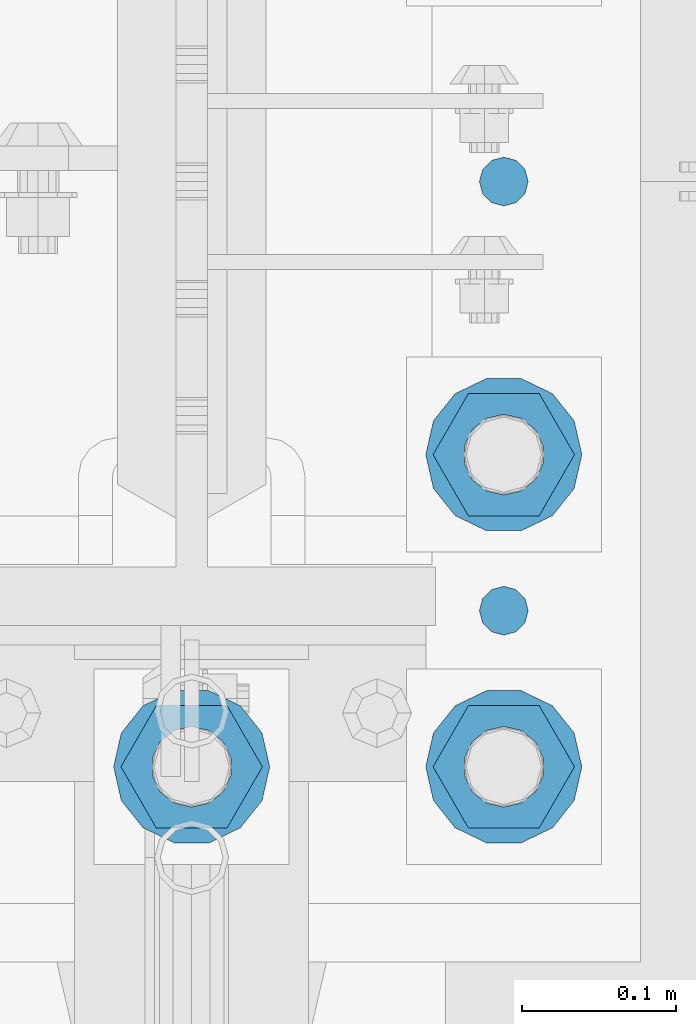
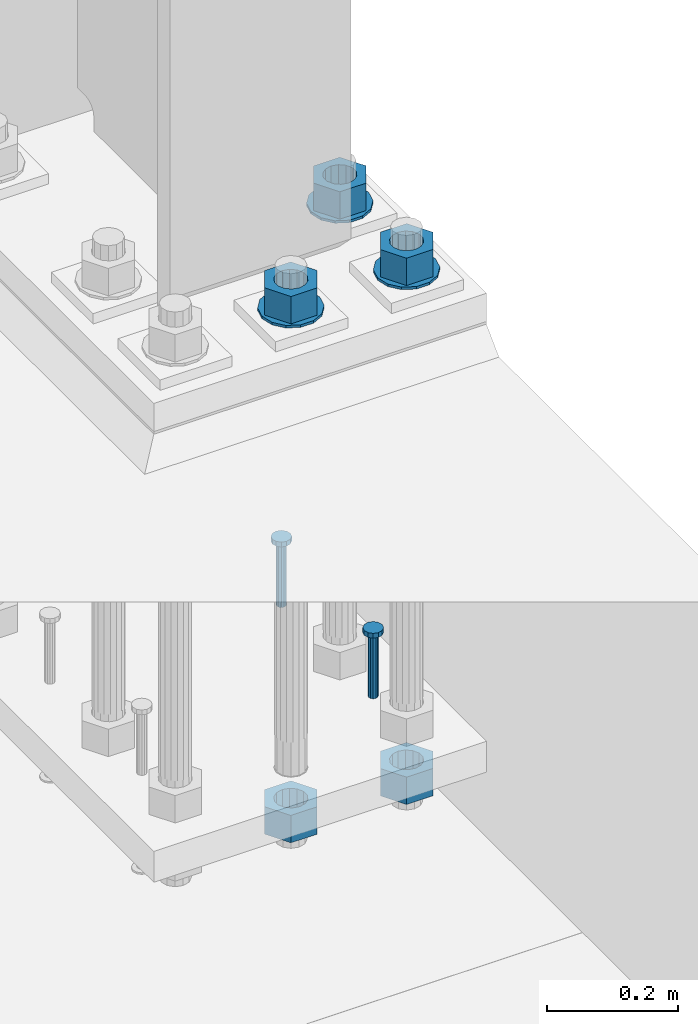
# One storey, part 857 of 1876: 10 columns, 1 element without a shape of its own.
"""IFC2X3 building model written with IfcOpenShell, lengths in millimetres."""

import ifcopenshell
import ifcopenshell.guid

model = None  # the IFC model being written
_history = None  # IfcOwnerHistory: only IFC2X3 demands one
_inside = {}  # id of a spatial element -> (the spatial element, [elements in it])
_under = {}  # id of a project, library or spatial element -> (it, [spatial elements below it])
_declared = {}  # id of a project -> (the project, [libraries it declares])
_typed = {}  # id of a type object -> (the type object, [elements of that type])
_made_of = {}  # id of a material, layer set ... -> (it, [elements and type objects made of it])


def new_model(schema):
    """Start an empty IFC model of exactly this schema.

    Asked for "IFC4X3", IfcOpenShell would pick the latest addendum, in which some entities
    have other attributes; the version numbers below select the first issue.
    IFC2X3 requires an IfcOwnerHistory on every rooted entity: one is made here for all.
    """
    global model, _history
    if schema == "IFC4X3":
        model = ifcopenshell.file(schema_version=(4, 3, 0, 0))
    else:
        model = ifcopenshell.file(schema=schema)
    _inside.clear()
    _under.clear()
    _declared.clear()
    _typed.clear()
    _made_of.clear()
    _history = None
    if model.schema == "IFC2X3":
        org = make("IfcOrganization", Name="unknown")
        user = make(
            "IfcPersonAndOrganization",
            ThePerson=make("IfcPerson", FamilyName="unknown"),
            TheOrganization=org,
        )
        app = make(
            "IfcApplication",
            ApplicationDeveloper=org,
            Version="unknown",
            ApplicationFullName="unknown",
            ApplicationIdentifier="unknown",
        )
        _history = make(
            "IfcOwnerHistory",
            OwningUser=user,
            OwningApplication=app,
            ChangeAction="ADDED",
            CreationDate=0,
        )
    return model


def make(cls, **values):
    """One entity of the class cls with the attributes given. An attribute that is None is left unset."""
    return model.create_entity(
        cls, **{name: value for name, value in values.items() if value is not None}
    )


def rooted(cls, **values):
    """An entity with a GlobalId (a new one), such as an element, a storey or a relation."""
    return make(cls, GlobalId=ifcopenshell.guid.new(), OwnerHistory=_history, **values)


def si_unit(unit_type, name, prefix=None):
    """IfcSIUnit, for example si_unit("LENGTHUNIT", "METRE", prefix="MILLI")."""
    return make("IfcSIUnit", UnitType=unit_type, Prefix=prefix, Name=name)


def assignment(units):
    """IfcUnitAssignment: the units of a project."""
    return None if units is None else make("IfcUnitAssignment", Units=units)


def point(xyz):
    """IfcCartesianPoint."""
    return None if xyz is None else make("IfcCartesianPoint", Coordinates=xyz)


def direction(xyz):
    """IfcDirection."""
    return None if xyz is None else make("IfcDirection", DirectionRatios=xyz)


def frame(location, z_axis=None, x_axis=None):
    """IfcAxis2Placement3D, a coordinate frame: its origin and axes. An axis left out is left unset."""
    return make(
        "IfcAxis2Placement3D",
        Location=point(location),
        Axis=direction(z_axis),
        RefDirection=direction(x_axis),
    )


def origin_with_axes():
    """The frame at (0, 0, 0) with the z axis (0, 0, 1) and the x axis (1, 0, 0) written out."""
    return frame((0.0, 0.0, 0.0), z_axis=(0.0, 0.0, 1.0), x_axis=(1.0, 0.0, 0.0))


def place(relative_to, where):
    """IfcLocalPlacement: puts the frame where relative to a parent placement (None: the world)."""
    return make(
        "IfcLocalPlacement", PlacementRelTo=relative_to, RelativePlacement=where
    )


def context(
    kind, dimensions, precision=None, world=None, true_north=None, identifier=None
):
    """IfcGeometricRepresentationContext, for example the 3D "Model" context."""
    return make(
        "IfcGeometricRepresentationContext",
        ContextIdentifier=identifier,
        ContextType=kind,
        CoordinateSpaceDimension=dimensions,
        Precision=precision,
        WorldCoordinateSystem=world,
        TrueNorth=true_north,
    )


def subcontext(parent, identifier, kind, view, scale=None):
    """IfcGeometricRepresentationSubContext, for example "Body" below "Model"."""
    return make(
        "IfcGeometricRepresentationSubContext",
        ContextIdentifier=identifier,
        ContextType=kind,
        ParentContext=parent,
        TargetScale=scale,
        TargetView=view,
    )


def project(units=None, contexts=None):
    """IfcProject with its units and contexts."""
    return rooted(
        "IfcProject",
        Name="project",
        RepresentationContexts=contexts,
        UnitsInContext=assignment(units),
    )


def spatial(cls, under=None, at=None, **own):
    """A site, building, storey or space (cls), placed at a placement, below another one or the project."""
    s = rooted(cls, ObjectPlacement=at, **own)
    if under is not None:
        _under.setdefault(under.id(), (under, []))[1].append(s)
    return s


def faces_of(points, faces, orient=None, outer=None):
    """IfcFace entities. A face is a list of loops; a loop is a list of indices into points, from 0.

    orient and outer hold one flag for each loop. By default every Orientation is true, the
    first loop of a face is its IfcFaceOuterBound and the others are IfcFaceBound.
    """
    made = []
    for i, loops in enumerate(faces):
        bounds = []
        for j, loop in enumerate(loops):
            is_outer = j == 0 if outer is None else outer[i][j]
            bounds.append(
                make(
                    "IfcFaceOuterBound" if is_outer else "IfcFaceBound",
                    Bound=make("IfcPolyLoop", Polygon=[points[k] for k in loop]),
                    Orientation=True if orient is None else orient[i][j],
                )
            )
        made.append(make("IfcFace", Bounds=bounds))
    return made


def faceted_brep(points, faces, orient=None, outer=None, voids=None):
    """IfcFacetedBrep: a solid bounded by flat faces; with voids (closed shells), ...WithVoids."""
    shared = [point(p) for p in points]
    hull = make("IfcClosedShell", CfsFaces=faces_of(shared, faces, orient, outer))
    if voids is None:
        return make("IfcFacetedBrep", Outer=hull)
    return make(
        "IfcFacetedBrepWithVoids",
        Outer=hull,
        Voids=[
            make(cls, CfsFaces=faces_of(shared, fs, o, b)) for cls, fs, o, b in voids
        ],
    )


def shape(context_of_items, identifier, shape_type, items):
    """IfcShapeRepresentation: the items that make up one representation, for example the "Body"."""
    return make(
        "IfcShapeRepresentation",
        ContextOfItems=context_of_items,
        RepresentationIdentifier=identifier,
        RepresentationType=shape_type,
        Items=items,
    )


def material(Name=None, Category=None):
    """IfcMaterial."""
    return make("IfcMaterial", Name=Name, Category=Category)


def made_of(thing, what):
    """Note that an element or type object is made of a material, layer set ...; save() writes the relation."""
    if what is not None:
        _made_of.setdefault(what.id(), (what, []))[1].append(thing)
    return thing


def type_object(cls, material=None, **own):
    """A type object (cls), such as IfcWallType, which elements share."""
    return made_of(rooted(cls, **own), material)


def element(
    cls,
    number,
    at=None,
    inside=None,
    cuts=None,
    type_object=None,
    material=None,
    context=None,
    identifier="Body",
    shape_type=None,
    held_by="IfcProductDefinitionShape",
    body=None,
    shapes=None,
    **own,
):
    """One element of the class cls, such as IfcWall. Its Tag is "e" and its number.

    at: its placement. inside: the storey or other place that contains it. cuts: it is an
    opening in that element (IfcRelVoidsElement). A single representation is given by context,
    identifier, shape_type and body (its items); several are given by shapes. held_by: the class
    of the entity that holds the representations. save() writes the other relations.
    """
    e = rooted(cls, Tag="e%d" % number, ObjectPlacement=at, **own)
    if body is not None:
        shapes = [shape(context, identifier, shape_type, body)]
    if shapes is not None:
        e.Representation = make(held_by, Representations=shapes)
    if inside is not None:
        _inside.setdefault(inside.id(), (inside, []))[1].append(e)
    if cuts is not None:
        rooted(
            "IfcRelVoidsElement", RelatingBuildingElement=cuts, RelatedOpeningElement=e
        )
    if type_object is not None:
        _typed.setdefault(type_object.id(), (type_object, []))[1].append(e)
    return made_of(e, material)


def aggregate(whole, parts):
    """IfcRelAggregates: a whole, such as a stair, and the parts it consists of."""
    return rooted("IfcRelAggregates", RelatingObject=whole, RelatedObjects=parts)


def save(model, path):
    """Write the relations noted so far, then the file.

    IfcRelAggregates (storeys below a building ...), IfcRelContainedInSpatialStructure (elements
    in a storey), IfcRelDefinesByType, IfcRelAssociatesMaterial and IfcRelDeclares: one each for
    every whole, place, type object, material and project.
    """
    for whole, parts in _under.values():
        aggregate(whole, parts)
    for where, things in _inside.values():
        rooted(
            "IfcRelContainedInSpatialStructure",
            RelatedElements=things,
            RelatingStructure=where,
        )
    for kind, things in _typed.values():
        rooted("IfcRelDefinesByType", RelatedObjects=things, RelatingType=kind)
    for what, things in _made_of.values():
        rooted("IfcRelAssociatesMaterial", RelatedObjects=things, RelatingMaterial=what)
    for by, libraries in _declared.values():
        rooted("IfcRelDeclares", RelatingContext=by, RelatedDefinitions=libraries)
    model.write(path)


model = new_model("IFC2X3")

# Units and contexts
model_context = context("Model", 3, precision=1e-05, world=origin_with_axes())
body_context = subcontext(model_context, "Body", "Model", "MODEL_VIEW")
ifc_project = project(units=[si_unit("LENGTHUNIT", "METRE", prefix="MILLI"), si_unit("AREAUNIT", "SQUARE_METRE"), si_unit("VOLUMEUNIT", "CUBIC_METRE"), si_unit("MASSUNIT", "GRAM", prefix="KILO"), si_unit("TIMEUNIT", "SECOND"), si_unit("PLANEANGLEUNIT", "RADIAN"), si_unit("SOLIDANGLEUNIT", "STERADIAN"), si_unit("THERMODYNAMICTEMPERATUREUNIT", "DEGREE_CELSIUS"), si_unit("LUMINOUSINTENSITYUNIT", "LUMEN")], contexts=[model_context])

# Site, building, storey
site_placement = place(None, origin_with_axes())
site = spatial("IfcSite", under=ifc_project, at=site_placement, CompositionType="ELEMENT")
building_placement = place(site_placement, origin_with_axes())
building = spatial("IfcBuilding", under=site, at=building_placement, Name="Undefined", CompositionType="ELEMENT")
storey_placement = place(building_placement, origin_with_axes())
storey = spatial("IfcBuildingStorey", under=building, at=storey_placement, Name="Undefined", CompositionType="ELEMENT", Elevation=0.0)

# Assembly, columns
assembly_placement = place(storey_placement, origin_with_axes())
assembly = element("IfcElementAssembly", 1, at=assembly_placement, inside=storey, Name="TEMPLATE", AssemblyPlace="NOTDEFINED", PredefinedType="RIGID_FRAME")
ifc_material_1 = material(Name="STEEL/F436")
column_type_1 = type_object("IfcColumnType", Name="2_WASHER", PredefinedType="NOTDEFINED")
column_1_placement = place(assembly_placement, frame((7620.0, 7239.0, 119.0625), z_axis=(0.0, -1.0, 0.0), x_axis=(0.0, 0.0, -1.0)))
column_1 = element("IfcColumn", 2, at=column_1_placement, type_object=column_type_1, material=ifc_material_1, Name="WASHER", ObjectType="2_WASHER", context=body_context, shape_type="Brep", body=[
    faceted_brep([(0.0, -50.7999992370605, 9.09494701772928e-13), (0.0, -45.7692178020588, -22.0412936161442), (4.7625, -45.7692178020588, -22.0412936161442), (4.7625, -50.7999992370605, 9.09494701772928e-13), (0.0, -31.6732814587394, -39.7170387128856), (4.7625, -31.6732814587394, -39.7170387128856), (0.0, -11.3040632752118, -49.5263371950259), (4.7625, -11.3040632752118, -49.5263371950259), (0.0, 11.30406327521, -49.5263371950264), (4.7625, 11.30406327521, -49.5263371950264), (0.0, 31.6732814587385, -39.7170387128867), (4.7625, 31.6732814587385, -39.7170387128867), (0.0, 45.7692178020579, -22.041293616146), (4.7625, 45.7692178020579, -22.041293616146), (0.0, 50.7999992370605, -9.09494701772928e-13), (4.7625, 50.7999992370605, -9.09494701772928e-13), (0.0, 45.7692178020588, 22.0412936161442), (4.7625, 45.7692178020588, 22.0412936161442), (0.0, 31.6732814587394, 39.7170387128856), (4.7625, 31.6732814587394, 39.7170387128856), (0.0, 11.3040632752118, 49.5263371950259), (4.7625, 11.3040632752118, 49.5263371950259), (0.0, -11.30406327521, 49.5263371950264), (4.7625, -11.30406327521, 49.5263371950264), (0.0, -31.6732814587385, 39.7170387128867), (4.7625, -31.6732814587385, 39.7170387128867), (0.0, -45.7692178020579, 22.041293616146), (4.7625, -45.7692178020579, 22.041293616146), (0.0, 0.0, 26.9869995117188), (0.0, 11.7093983825444, 24.3146012721213), (4.7625, 11.7093983825444, 24.3146012721213), (4.7625, 0.0, 26.9869995117188), (0.0, 21.0996520289491, 16.8262864224157), (4.7625, 21.0996520289491, 16.8262864224157), (0.0, 26.3108629296712, 6.00524193584533), (4.7625, 26.3108629296712, 6.00524193584533), (0.0, 26.3108629296712, -6.00524193584533), (4.7625, 26.3108629296712, -6.00524193584533), (0.0, 21.0996520289491, -16.8262864224157), (4.7625, 21.0996520289491, -16.8262864224157), (0.0, 11.7093983825444, -24.3146012721213), (4.7625, 11.7093983825444, -24.3146012721213), (0.0, 0.0, -26.9869995117188), (4.7625, 0.0, -26.9869995117188), (0.0, -11.7093983825444, -24.3146012721213), (4.7625, -11.7093983825444, -24.3146012721213), (0.0, -21.0996520289491, -16.8262864224157), (4.7625, -21.0996520289491, -16.8262864224157), (0.0, -26.3108629296712, -6.00524193584533), (4.7625, -26.3108629296712, -6.00524193584533), (0.0, -26.3108629296712, 6.00524193584533), (4.7625, -26.3108629296712, 6.00524193584533), (0.0, -21.0996520289491, 16.8262864224157), (4.7625, -21.0996520289491, 16.8262864224157), (0.0, -11.7093983825444, 24.3146012721213), (4.7625, -11.7093983825444, 24.3146012721213)], [[[0, 1, 2, 3]], [[1, 4, 5, 2]], [[4, 6, 7, 5]], [[6, 8, 9, 7]], [[8, 10, 11, 9]], [[10, 12, 13, 11]], [[12, 14, 15, 13]], [[14, 16, 17, 15]], [[16, 18, 19, 17]], [[18, 20, 21, 19]], [[20, 22, 23, 21]], [[22, 24, 25, 23]], [[24, 26, 27, 25]], [[26, 0, 3, 27]], [[28, 29, 30, 31]], [[29, 32, 33, 30]], [[32, 34, 35, 33]], [[34, 36, 37, 35]], [[36, 38, 39, 37]], [[38, 40, 41, 39]], [[40, 42, 43, 41]], [[42, 44, 45, 43]], [[44, 46, 47, 45]], [[46, 48, 49, 47]], [[48, 50, 51, 49]], [[50, 52, 53, 51]], [[52, 54, 55, 53]], [[54, 28, 31, 55]], [[5, 7, 9, 11, 13, 15, 17, 19, 21, 23, 25, 27, 3, 2], [33, 35, 37, 39, 41, 43, 45, 47, 49, 51, 53, 55, 31, 30]], [[26, 24, 22, 20, 18, 16, 14, 12, 10, 8, 6, 4, 1, 0], [54, 52, 50, 48, 46, 44, 42, 40, 38, 36, 34, 32, 29, 28]]]),
])
column_2_placement = place(assembly_placement, frame((7823.2, 7239.0, 119.0625), z_axis=(0.0, 1.0, 0.0), x_axis=(0.0, 0.0, -1.0)))
column_2 = element("IfcColumn", 3, at=column_2_placement, type_object=column_type_1, material=ifc_material_1, Name="WASHER", ObjectType="2_WASHER", context=body_context, shape_type="Brep", body=[
    faceted_brep([(0.0, -50.7999992370605, 9.09494701772928e-13), (0.0, -45.7692178020588, -22.0412936161442), (4.7625, -45.7692178020588, -22.0412936161442), (4.7625, -50.7999992370605, 9.09494701772928e-13), (0.0, -31.6732814587394, -39.7170387128856), (4.7625, -31.6732814587394, -39.7170387128856), (0.0, -11.3040632752118, -49.5263371950259), (4.7625, -11.3040632752118, -49.5263371950259), (0.0, 11.30406327521, -49.5263371950264), (4.7625, 11.30406327521, -49.5263371950264), (0.0, 31.6732814587385, -39.7170387128867), (4.7625, 31.6732814587385, -39.7170387128867), (0.0, 45.7692178020579, -22.041293616146), (4.7625, 45.7692178020579, -22.041293616146), (0.0, 50.7999992370605, -9.09494701772928e-13), (4.7625, 50.7999992370605, -9.09494701772928e-13), (0.0, 45.7692178020588, 22.0412936161442), (4.7625, 45.7692178020588, 22.0412936161442), (0.0, 31.6732814587394, 39.7170387128856), (4.7625, 31.6732814587394, 39.7170387128856), (0.0, 11.3040632752118, 49.5263371950259), (4.7625, 11.3040632752118, 49.5263371950259), (0.0, -11.30406327521, 49.5263371950264), (4.7625, -11.30406327521, 49.5263371950264), (0.0, -31.6732814587385, 39.7170387128867), (4.7625, -31.6732814587385, 39.7170387128867), (0.0, -45.7692178020579, 22.041293616146), (4.7625, -45.7692178020579, 22.041293616146), (0.0, 0.0, 26.9869995117188), (0.0, 11.7093983825444, 24.3146012721213), (4.7625, 11.7093983825444, 24.3146012721213), (4.7625, 0.0, 26.9869995117188), (0.0, 21.0996520289491, 16.8262864224157), (4.7625, 21.0996520289491, 16.8262864224157), (0.0, 26.3108629296712, 6.00524193584533), (4.7625, 26.3108629296712, 6.00524193584533), (0.0, 26.3108629296712, -6.00524193584533), (4.7625, 26.3108629296712, -6.00524193584533), (0.0, 21.0996520289491, -16.8262864224157), (4.7625, 21.0996520289491, -16.8262864224157), (0.0, 11.7093983825444, -24.3146012721213), (4.7625, 11.7093983825444, -24.3146012721213), (0.0, 0.0, -26.9869995117188), (4.7625, 0.0, -26.9869995117188), (0.0, -11.7093983825444, -24.3146012721213), (4.7625, -11.7093983825444, -24.3146012721213), (0.0, -21.0996520289491, -16.8262864224157), (4.7625, -21.0996520289491, -16.8262864224157), (0.0, -26.3108629296712, -6.00524193584533), (4.7625, -26.3108629296712, -6.00524193584533), (0.0, -26.3108629296712, 6.00524193584533), (4.7625, -26.3108629296712, 6.00524193584533), (0.0, -21.0996520289491, 16.8262864224157), (4.7625, -21.0996520289491, 16.8262864224157), (0.0, -11.7093983825444, 24.3146012721213), (4.7625, -11.7093983825444, 24.3146012721213)], [[[0, 1, 2, 3]], [[1, 4, 5, 2]], [[4, 6, 7, 5]], [[6, 8, 9, 7]], [[8, 10, 11, 9]], [[10, 12, 13, 11]], [[12, 14, 15, 13]], [[14, 16, 17, 15]], [[16, 18, 19, 17]], [[18, 20, 21, 19]], [[20, 22, 23, 21]], [[22, 24, 25, 23]], [[24, 26, 27, 25]], [[26, 0, 3, 27]], [[28, 29, 30, 31]], [[29, 32, 33, 30]], [[32, 34, 35, 33]], [[34, 36, 37, 35]], [[36, 38, 39, 37]], [[38, 40, 41, 39]], [[40, 42, 43, 41]], [[42, 44, 45, 43]], [[44, 46, 47, 45]], [[46, 48, 49, 47]], [[48, 50, 51, 49]], [[50, 52, 53, 51]], [[52, 54, 55, 53]], [[54, 28, 31, 55]], [[5, 7, 9, 11, 13, 15, 17, 19, 21, 23, 25, 27, 3, 2], [33, 35, 37, 39, 41, 43, 45, 47, 49, 51, 53, 55, 31, 30]], [[26, 24, 22, 20, 18, 16, 14, 12, 10, 8, 6, 4, 1, 0], [54, 52, 50, 48, 46, 44, 42, 40, 38, 36, 34, 32, 29, 28]]]),
])
column_3_placement = place(assembly_placement, frame((7823.2, 7442.2, 119.0625), z_axis=(0.0, 1.0, 0.0), x_axis=(0.0, 0.0, -1.0)))
column_3 = element("IfcColumn", 4, at=column_3_placement, type_object=column_type_1, material=ifc_material_1, Name="WASHER", ObjectType="2_WASHER", context=body_context, shape_type="Brep", body=[
    faceted_brep([(0.0, -50.7999992370605, 9.09494701772928e-13), (0.0, -45.7692178020588, -22.0412936161442), (4.7625, -45.7692178020588, -22.0412936161442), (4.7625, -50.7999992370605, 9.09494701772928e-13), (0.0, -31.6732814587394, -39.7170387128856), (4.7625, -31.6732814587394, -39.7170387128856), (0.0, -11.3040632752118, -49.5263371950259), (4.7625, -11.3040632752118, -49.5263371950259), (0.0, 11.30406327521, -49.5263371950264), (4.7625, 11.30406327521, -49.5263371950264), (0.0, 31.6732814587385, -39.7170387128867), (4.7625, 31.6732814587385, -39.7170387128867), (0.0, 45.7692178020579, -22.041293616146), (4.7625, 45.7692178020579, -22.041293616146), (0.0, 50.7999992370605, -9.09494701772928e-13), (4.7625, 50.7999992370605, -9.09494701772928e-13), (0.0, 45.7692178020588, 22.0412936161442), (4.7625, 45.7692178020588, 22.0412936161442), (0.0, 31.6732814587394, 39.7170387128856), (4.7625, 31.6732814587394, 39.7170387128856), (0.0, 11.3040632752118, 49.5263371950259), (4.7625, 11.3040632752118, 49.5263371950259), (0.0, -11.30406327521, 49.5263371950264), (4.7625, -11.30406327521, 49.5263371950264), (0.0, -31.6732814587385, 39.7170387128867), (4.7625, -31.6732814587385, 39.7170387128867), (0.0, -45.7692178020579, 22.041293616146), (4.7625, -45.7692178020579, 22.041293616146), (0.0, 0.0, 26.9869995117188), (0.0, 11.7093983825444, 24.3146012721213), (4.7625, 11.7093983825444, 24.3146012721213), (4.7625, 0.0, 26.9869995117188), (0.0, 21.0996520289491, 16.8262864224157), (4.7625, 21.0996520289491, 16.8262864224157), (0.0, 26.3108629296712, 6.00524193584533), (4.7625, 26.3108629296712, 6.00524193584533), (0.0, 26.3108629296712, -6.00524193584533), (4.7625, 26.3108629296712, -6.00524193584533), (0.0, 21.0996520289491, -16.8262864224157), (4.7625, 21.0996520289491, -16.8262864224157), (0.0, 11.7093983825444, -24.3146012721213), (4.7625, 11.7093983825444, -24.3146012721213), (0.0, 0.0, -26.9869995117188), (4.7625, 0.0, -26.9869995117188), (0.0, -11.7093983825444, -24.3146012721213), (4.7625, -11.7093983825444, -24.3146012721213), (0.0, -21.0996520289491, -16.8262864224157), (4.7625, -21.0996520289491, -16.8262864224157), (0.0, -26.3108629296712, -6.00524193584533), (4.7625, -26.3108629296712, -6.00524193584533), (0.0, -26.3108629296712, 6.00524193584533), (4.7625, -26.3108629296712, 6.00524193584533), (0.0, -21.0996520289491, 16.8262864224157), (4.7625, -21.0996520289491, 16.8262864224157), (0.0, -11.7093983825444, 24.3146012721213), (4.7625, -11.7093983825444, 24.3146012721213)], [[[0, 1, 2, 3]], [[1, 4, 5, 2]], [[4, 6, 7, 5]], [[6, 8, 9, 7]], [[8, 10, 11, 9]], [[10, 12, 13, 11]], [[12, 14, 15, 13]], [[14, 16, 17, 15]], [[16, 18, 19, 17]], [[18, 20, 21, 19]], [[20, 22, 23, 21]], [[22, 24, 25, 23]], [[24, 26, 27, 25]], [[26, 0, 3, 27]], [[28, 29, 30, 31]], [[29, 32, 33, 30]], [[32, 34, 35, 33]], [[34, 36, 37, 35]], [[36, 38, 39, 37]], [[38, 40, 41, 39]], [[40, 42, 43, 41]], [[42, 44, 45, 43]], [[44, 46, 47, 45]], [[46, 48, 49, 47]], [[48, 50, 51, 49]], [[50, 52, 53, 51]], [[52, 54, 55, 53]], [[54, 28, 31, 55]], [[5, 7, 9, 11, 13, 15, 17, 19, 21, 23, 25, 27, 3, 2], [33, 35, 37, 39, 41, 43, 45, 47, 49, 51, 53, 55, 31, 30]], [[26, 24, 22, 20, 18, 16, 14, 12, 10, 8, 6, 4, 1, 0], [54, 52, 50, 48, 46, 44, 42, 40, 38, 36, 34, 32, 29, 28]]]),
])
ifc_material_2 = material(Name="STEEL/A108")
column_type_2 = type_object("IfcColumnType", Name="5/8-DIA_HEADED ANCHOR STUD", PredefinedType="NOTDEFINED")
column_4_placement = place(assembly_placement, frame((7823.2, 7340.6, -736.6), z_axis=(1.0, 0.0, 0.0), x_axis=(0.0, 0.0, 1.0)))
column_4 = element("IfcColumn", 5, at=column_4_placement, type_object=column_type_2, material=ifc_material_2, Name="HEADED ANCHOR STUD", ObjectType="5/8-DIA_HEADED ANCHOR STUD", context=body_context, shape_type="Brep", body=[
    faceted_brep([(0.0, -7.94000005722046, 0.0), (0.0, -6.86999988555908, -3.97000002861023), (116.84, -6.86999988555908, -3.97000002861023), (116.84, -7.94000005722046, 0.0), (0.0, -3.97000002861023, -6.86999988555908), (116.84, -3.97000002861023, -6.86999988555908), (0.0, 0.0, -7.94000005722046), (116.84, 0.0, -7.94000005722046), (0.0, 3.97000002861023, -6.86999988555908), (116.84, 3.97000002861023, -6.86999988555908), (0.0, 6.86999988555908, -3.97000002861023), (116.84, 6.86999988555908, -3.97000002861023), (0.0, 7.94000005722046, 0.0), (116.84, 7.94000005722046, 0.0), (0.0, 6.86999988555908, 3.97000002861023), (116.84, 6.86999988555908, 3.97000002861023), (0.0, 3.97000002861023, 6.86999988555908), (116.84, 3.97000002861023, 6.86999988555908), (0.0, 0.0, 7.94000005722046), (116.84, 0.0, 7.94000005722046), (0.0, -3.97000002861023, 6.86999988555908), (116.84, -3.97000002861023, 6.86999988555908), (0.0, -6.86999988555908, 3.97000002861023), (116.84, -6.86999988555908, 3.97000002861023), (118.11, -13.75, -7.94000005722046), (118.11, -15.8800001144409, 0.0), (118.11, -7.94000005722046, -13.75), (118.11, 0.0, -15.8800001144409), (118.11, 7.94000005722046, -13.75), (118.11, 13.75, -7.94000005722046), (118.11, 15.8800001144409, 0.0), (118.11, 13.75, 7.94000005722046), (118.11, 7.94000005722046, 13.75), (118.11, 0.0, 15.8800001144409), (118.11, -7.94000005722046, 13.75), (118.11, -13.75, 7.94000005722046), (127.0, -13.75, -7.94000005722046), (127.0, -15.8800001144409, 0.0), (127.0, -7.94000005722046, -13.75), (127.0, 0.0, -15.8800001144409), (127.0, 7.94000005722046, -13.75), (127.0, 13.75, -7.94000005722046), (127.0, 15.8800001144409, 0.0), (127.0, 13.75, 7.94000005722046), (127.0, 7.94000005722046, 13.75), (127.0, 0.0, 15.8800001144409), (127.0, -7.94000005722046, 13.75), (127.0, -13.75, 7.94000005722046)], [[[0, 1, 2, 3]], [[1, 4, 5, 2]], [[4, 6, 7, 5]], [[6, 8, 9, 7]], [[8, 10, 11, 9]], [[10, 12, 13, 11]], [[12, 14, 15, 13]], [[14, 16, 17, 15]], [[16, 18, 19, 17]], [[18, 20, 21, 19]], [[20, 22, 23, 21]], [[22, 0, 3, 23]], [[22, 20, 18, 16, 14, 12, 10, 8, 6, 4, 1, 0]], [[3, 2, 24, 25]], [[2, 5, 26, 24]], [[5, 7, 27, 26]], [[7, 9, 28, 27]], [[9, 11, 29, 28]], [[11, 13, 30, 29]], [[13, 15, 31, 30]], [[15, 17, 32, 31]], [[17, 19, 33, 32]], [[19, 21, 34, 33]], [[21, 23, 35, 34]], [[23, 3, 25, 35]], [[25, 24, 36, 37]], [[24, 26, 38, 36]], [[26, 27, 39, 38]], [[27, 28, 40, 39]], [[28, 29, 41, 40]], [[29, 30, 42, 41]], [[30, 31, 43, 42]], [[31, 32, 44, 43]], [[32, 33, 45, 44]], [[33, 34, 46, 45]], [[34, 35, 47, 46]], [[35, 25, 37, 47]], [[38, 39, 40, 41, 42, 43, 44, 45, 46, 47, 37, 36]]]),
])
column_5_placement = place(assembly_placement, frame((7823.2, 7620.0, -736.6), z_axis=(1.0, 0.0, 0.0), x_axis=(0.0, 0.0, 1.0)))
column_5 = element("IfcColumn", 6, at=column_5_placement, type_object=column_type_2, material=ifc_material_2, Name="HEADED ANCHOR STUD", ObjectType="5/8-DIA_HEADED ANCHOR STUD", context=body_context, shape_type="Brep", body=[
    faceted_brep([(0.0, -7.94000005722046, 0.0), (0.0, -6.86999988555908, -3.97000002861023), (116.84, -6.86999988555908, -3.97000002861023), (116.84, -7.94000005722046, 0.0), (0.0, -3.97000002861023, -6.86999988555908), (116.84, -3.97000002861023, -6.86999988555908), (0.0, 0.0, -7.94000005722046), (116.84, 0.0, -7.94000005722046), (0.0, 3.97000002861023, -6.86999988555908), (116.84, 3.97000002861023, -6.86999988555908), (0.0, 6.86999988555908, -3.97000002861023), (116.84, 6.86999988555908, -3.97000002861023), (0.0, 7.94000005722046, 0.0), (116.84, 7.94000005722046, 0.0), (0.0, 6.86999988555908, 3.97000002861023), (116.84, 6.86999988555908, 3.97000002861023), (0.0, 3.97000002861023, 6.86999988555908), (116.84, 3.97000002861023, 6.86999988555908), (0.0, 0.0, 7.94000005722046), (116.84, 0.0, 7.94000005722046), (0.0, -3.97000002861023, 6.86999988555908), (116.84, -3.97000002861023, 6.86999988555908), (0.0, -6.86999988555908, 3.97000002861023), (116.84, -6.86999988555908, 3.97000002861023), (118.11, -13.75, -7.94000005722046), (118.11, -15.8800001144409, 0.0), (118.11, -7.94000005722046, -13.75), (118.11, 0.0, -15.8800001144409), (118.11, 7.94000005722046, -13.75), (118.11, 13.75, -7.94000005722046), (118.11, 15.8800001144409, 0.0), (118.11, 13.75, 7.94000005722046), (118.11, 7.94000005722046, 13.75), (118.11, 0.0, 15.8800001144409), (118.11, -7.94000005722046, 13.75), (118.11, -13.75, 7.94000005722046), (127.0, -13.75, -7.94000005722046), (127.0, -15.8800001144409, 0.0), (127.0, -7.94000005722046, -13.75), (127.0, 0.0, -15.8800001144409), (127.0, 7.94000005722046, -13.75), (127.0, 13.75, -7.94000005722046), (127.0, 15.8800001144409, 0.0), (127.0, 13.75, 7.94000005722046), (127.0, 7.94000005722046, 13.75), (127.0, 0.0, 15.8800001144409), (127.0, -7.94000005722046, 13.75), (127.0, -13.75, 7.94000005722046)], [[[0, 1, 2, 3]], [[1, 4, 5, 2]], [[4, 6, 7, 5]], [[6, 8, 9, 7]], [[8, 10, 11, 9]], [[10, 12, 13, 11]], [[12, 14, 15, 13]], [[14, 16, 17, 15]], [[16, 18, 19, 17]], [[18, 20, 21, 19]], [[20, 22, 23, 21]], [[22, 0, 3, 23]], [[22, 20, 18, 16, 14, 12, 10, 8, 6, 4, 1, 0]], [[3, 2, 24, 25]], [[2, 5, 26, 24]], [[5, 7, 27, 26]], [[7, 9, 28, 27]], [[9, 11, 29, 28]], [[11, 13, 30, 29]], [[13, 15, 31, 30]], [[15, 17, 32, 31]], [[17, 19, 33, 32]], [[19, 21, 34, 33]], [[21, 23, 35, 34]], [[23, 3, 25, 35]], [[25, 24, 36, 37]], [[24, 26, 38, 36]], [[26, 27, 39, 38]], [[27, 28, 40, 39]], [[28, 29, 41, 40]], [[29, 30, 42, 41]], [[30, 31, 43, 42]], [[31, 32, 44, 43]], [[32, 33, 45, 44]], [[33, 34, 46, 45]], [[34, 35, 47, 46]], [[35, 25, 37, 47]], [[38, 39, 40, 41, 42, 43, 44, 45, 46, 47, 37, 36]]]),
])
ifc_material_3 = material(Name="STEEL/A563")
column_type_3 = type_object("IfcColumnType", Name="2_HEAVY_HEX_NUT", PredefinedType="NOTDEFINED")
column_6_placement = place(assembly_placement, frame((7620.0, 7239.0, 169.8625), z_axis=(0.0, -1.0, 0.0), x_axis=(0.0, 0.0, -1.0)))
column_6 = element("IfcColumn", 7, at=column_6_placement, type_object=column_type_3, material=ifc_material_3, Name="NUT", ObjectType="2_HEAVY_HEX_NUT", context=body_context, shape_type="Brep", body=[
    faceted_brep([(0.0, -46.0369987487793, 9.09494701772928e-13), (0.0, -23.0184993743896, -39.869213104248), (50.8, -23.0184993743896, -39.869213104248), (50.8, -46.0369987487793, 9.09494701772928e-13), (0.0, 23.0184993743896, -39.869213104248), (50.8, 23.0184993743896, -39.869213104248), (0.0, 46.0369987487793, -9.09494701772928e-13), (50.8, 46.0369987487793, -9.09494701772928e-13), (0.0, 23.0184993743896, 39.869213104248), (50.8, 23.0184993743896, 39.869213104248), (0.0, -23.0184993743896, 39.869213104248), (50.8, -23.0184993743896, 39.869213104248), (0.0, 0.0, 26.1940002441406), (0.0, 11.3650617044514, 23.5999013092769), (50.8, 11.3650617044513, 23.5999013092771), (50.8, 0.0, 26.1940002441406), (0.0, 20.4791109456437, 16.3316083006703), (50.8, 20.4791109456439, 16.3316083006703), (0.0, 25.5370200498346, 5.82867859874477), (50.8, 25.5370200498343, 5.82867859874455), (0.0, 25.5370200498346, -5.82867859874477), (50.8, 25.5370200498343, -5.82867859874455), (0.0, 20.4791109456437, -16.3316083006703), (50.8, 20.4791109456439, -16.3316083006703), (0.0, 11.3650617044514, -23.5999013092769), (50.8, 11.3650617044514, -23.5999013092771), (0.0, 0.0, -26.1940002441406), (50.8, 0.0, -26.1940002441406), (0.0, -11.3650617044514, -23.5999013092769), (50.8, -11.3650617044513, -23.5999013092771), (0.0, -20.4791109456437, -16.3316083006703), (50.8, -20.4791109456439, -16.3316083006703), (0.0, -25.5370200498346, -5.82867859874477), (50.8, -25.5370200498343, -5.82867859874455), (0.0, -25.5370200498346, 5.82867859874477), (50.8, -25.5370200498343, 5.82867859874455), (0.0, -20.4791109456437, 16.3316083006703), (50.8, -20.4791109456439, 16.3316083006703), (0.0, -11.3650617044514, 23.5999013092769), (50.8, -11.3650617044514, 23.5999013092771)], [[[0, 1, 2, 3]], [[1, 4, 5, 2]], [[4, 6, 7, 5]], [[6, 8, 9, 7]], [[8, 10, 11, 9]], [[10, 0, 3, 11]], [[12, 13, 14, 15]], [[13, 16, 17, 14]], [[16, 18, 19, 17]], [[18, 20, 21, 19]], [[20, 22, 23, 21]], [[22, 24, 25, 23]], [[24, 26, 27, 25]], [[26, 28, 29, 27]], [[28, 30, 31, 29]], [[30, 32, 33, 31]], [[32, 34, 35, 33]], [[34, 36, 37, 35]], [[36, 38, 39, 37]], [[38, 12, 15, 39]], [[5, 7, 9, 11, 3, 2], [17, 19, 21, 23, 25, 27, 29, 31, 33, 35, 37, 39, 15, 14]], [[10, 8, 6, 4, 1, 0], [38, 36, 34, 32, 30, 28, 26, 24, 22, 20, 18, 16, 13, 12]]]),
])
column_7_placement = place(assembly_placement, frame((7620.0, 7239.0, -793.75), z_axis=(0.0, -1.0, 0.0), x_axis=(0.0, 0.0, -1.0)))
column_7 = element("IfcColumn", 8, at=column_7_placement, type_object=column_type_3, material=ifc_material_3, Name="NUT", ObjectType="2_HEAVY_HEX_NUT", context=body_context, shape_type="Brep", body=[
    faceted_brep([(0.0, -46.0369987487793, 9.09494701772928e-13), (0.0, -23.0184993743896, -39.869213104248), (50.8, -23.0184993743896, -39.869213104248), (50.8, -46.0369987487793, 9.09494701772928e-13), (0.0, 23.0184993743896, -39.869213104248), (50.8, 23.0184993743896, -39.869213104248), (0.0, 46.0369987487793, -9.09494701772928e-13), (50.8, 46.0369987487793, -9.09494701772928e-13), (0.0, 23.0184993743896, 39.869213104248), (50.8, 23.0184993743896, 39.869213104248), (0.0, -23.0184993743896, 39.869213104248), (50.8, -23.0184993743896, 39.869213104248), (0.0, 0.0, 26.1940002441406), (0.0, 11.3650617044514, 23.5999013092769), (50.8, 11.3650617044513, 23.5999013092771), (50.8, 0.0, 26.1940002441406), (0.0, 20.4791109456437, 16.3316083006703), (50.8, 20.4791109456439, 16.3316083006703), (0.0, 25.5370200498346, 5.82867859874477), (50.8, 25.5370200498343, 5.82867859874455), (0.0, 25.5370200498346, -5.82867859874477), (50.8, 25.5370200498343, -5.82867859874455), (0.0, 20.4791109456437, -16.3316083006703), (50.8, 20.4791109456439, -16.3316083006703), (0.0, 11.3650617044514, -23.5999013092769), (50.8, 11.3650617044514, -23.5999013092771), (0.0, 0.0, -26.1940002441406), (50.8, 0.0, -26.1940002441406), (0.0, -11.3650617044514, -23.5999013092769), (50.8, -11.3650617044513, -23.5999013092771), (0.0, -20.4791109456437, -16.3316083006703), (50.8, -20.4791109456439, -16.3316083006703), (0.0, -25.5370200498346, -5.82867859874477), (50.8, -25.5370200498343, -5.82867859874455), (0.0, -25.5370200498346, 5.82867859874477), (50.8, -25.5370200498343, 5.82867859874455), (0.0, -20.4791109456437, 16.3316083006703), (50.8, -20.4791109456439, 16.3316083006703), (0.0, -11.3650617044514, 23.5999013092769), (50.8, -11.3650617044514, 23.5999013092771)], [[[0, 1, 2, 3]], [[1, 4, 5, 2]], [[4, 6, 7, 5]], [[6, 8, 9, 7]], [[8, 10, 11, 9]], [[10, 0, 3, 11]], [[12, 13, 14, 15]], [[13, 16, 17, 14]], [[16, 18, 19, 17]], [[18, 20, 21, 19]], [[20, 22, 23, 21]], [[22, 24, 25, 23]], [[24, 26, 27, 25]], [[26, 28, 29, 27]], [[28, 30, 31, 29]], [[30, 32, 33, 31]], [[32, 34, 35, 33]], [[34, 36, 37, 35]], [[36, 38, 39, 37]], [[38, 12, 15, 39]], [[5, 7, 9, 11, 3, 2], [17, 19, 21, 23, 25, 27, 29, 31, 33, 35, 37, 39, 15, 14]], [[10, 8, 6, 4, 1, 0], [38, 36, 34, 32, 30, 28, 26, 24, 22, 20, 18, 16, 13, 12]]]),
])
column_8_placement = place(assembly_placement, frame((7823.2, 7239.0, 169.8625), z_axis=(0.0, 1.0, 0.0), x_axis=(0.0, 0.0, -1.0)))
column_8 = element("IfcColumn", 9, at=column_8_placement, type_object=column_type_3, material=ifc_material_3, Name="NUT", ObjectType="2_HEAVY_HEX_NUT", context=body_context, shape_type="Brep", body=[
    faceted_brep([(0.0, -46.0369987487793, 9.09494701772928e-13), (0.0, -23.0184993743896, -39.869213104248), (50.8, -23.0184993743896, -39.869213104248), (50.8, -46.0369987487793, 9.09494701772928e-13), (0.0, 23.0184993743896, -39.869213104248), (50.8, 23.0184993743896, -39.869213104248), (0.0, 46.0369987487793, -9.09494701772928e-13), (50.8, 46.0369987487793, -9.09494701772928e-13), (0.0, 23.0184993743896, 39.869213104248), (50.8, 23.0184993743896, 39.869213104248), (0.0, -23.0184993743896, 39.869213104248), (50.8, -23.0184993743896, 39.869213104248), (0.0, 0.0, 26.1940002441406), (0.0, 11.3650617044514, 23.5999013092769), (50.8, 11.3650617044513, 23.5999013092771), (50.8, 0.0, 26.1940002441406), (0.0, 20.4791109456437, 16.3316083006703), (50.8, 20.4791109456439, 16.3316083006703), (0.0, 25.5370200498346, 5.82867859874477), (50.8, 25.5370200498343, 5.82867859874455), (0.0, 25.5370200498346, -5.82867859874477), (50.8, 25.5370200498343, -5.82867859874455), (0.0, 20.4791109456437, -16.3316083006703), (50.8, 20.4791109456439, -16.3316083006703), (0.0, 11.3650617044514, -23.5999013092769), (50.8, 11.3650617044514, -23.5999013092771), (0.0, 0.0, -26.1940002441406), (50.8, 0.0, -26.1940002441406), (0.0, -11.3650617044514, -23.5999013092769), (50.8, -11.3650617044513, -23.5999013092771), (0.0, -20.4791109456437, -16.3316083006703), (50.8, -20.4791109456439, -16.3316083006703), (0.0, -25.5370200498346, -5.82867859874477), (50.8, -25.5370200498343, -5.82867859874455), (0.0, -25.5370200498346, 5.82867859874477), (50.8, -25.5370200498343, 5.82867859874455), (0.0, -20.4791109456437, 16.3316083006703), (50.8, -20.4791109456439, 16.3316083006703), (0.0, -11.3650617044514, 23.5999013092769), (50.8, -11.3650617044514, 23.5999013092771)], [[[0, 1, 2, 3]], [[1, 4, 5, 2]], [[4, 6, 7, 5]], [[6, 8, 9, 7]], [[8, 10, 11, 9]], [[10, 0, 3, 11]], [[12, 13, 14, 15]], [[13, 16, 17, 14]], [[16, 18, 19, 17]], [[18, 20, 21, 19]], [[20, 22, 23, 21]], [[22, 24, 25, 23]], [[24, 26, 27, 25]], [[26, 28, 29, 27]], [[28, 30, 31, 29]], [[30, 32, 33, 31]], [[32, 34, 35, 33]], [[34, 36, 37, 35]], [[36, 38, 39, 37]], [[38, 12, 15, 39]], [[5, 7, 9, 11, 3, 2], [17, 19, 21, 23, 25, 27, 29, 31, 33, 35, 37, 39, 15, 14]], [[10, 8, 6, 4, 1, 0], [38, 36, 34, 32, 30, 28, 26, 24, 22, 20, 18, 16, 13, 12]]]),
])
column_9_placement = place(assembly_placement, frame((7823.2, 7239.0, -793.75), z_axis=(0.0, 1.0, 0.0), x_axis=(0.0, 0.0, -1.0)))
column_9 = element("IfcColumn", 10, at=column_9_placement, type_object=column_type_3, material=ifc_material_3, Name="NUT", ObjectType="2_HEAVY_HEX_NUT", context=body_context, shape_type="Brep", body=[
    faceted_brep([(0.0, -46.0369987487793, 9.09494701772928e-13), (0.0, -23.0184993743896, -39.869213104248), (50.8, -23.0184993743896, -39.869213104248), (50.8, -46.0369987487793, 9.09494701772928e-13), (0.0, 23.0184993743896, -39.869213104248), (50.8, 23.0184993743896, -39.869213104248), (0.0, 46.0369987487793, -9.09494701772928e-13), (50.8, 46.0369987487793, -9.09494701772928e-13), (0.0, 23.0184993743896, 39.869213104248), (50.8, 23.0184993743896, 39.869213104248), (0.0, -23.0184993743896, 39.869213104248), (50.8, -23.0184993743896, 39.869213104248), (0.0, 0.0, 26.1940002441406), (0.0, 11.3650617044514, 23.5999013092769), (50.8, 11.3650617044513, 23.5999013092771), (50.8, 0.0, 26.1940002441406), (0.0, 20.4791109456437, 16.3316083006703), (50.8, 20.4791109456439, 16.3316083006703), (0.0, 25.5370200498346, 5.82867859874477), (50.8, 25.5370200498343, 5.82867859874455), (0.0, 25.5370200498346, -5.82867859874477), (50.8, 25.5370200498343, -5.82867859874455), (0.0, 20.4791109456437, -16.3316083006703), (50.8, 20.4791109456439, -16.3316083006703), (0.0, 11.3650617044514, -23.5999013092769), (50.8, 11.3650617044514, -23.5999013092771), (0.0, 0.0, -26.1940002441406), (50.8, 0.0, -26.1940002441406), (0.0, -11.3650617044514, -23.5999013092769), (50.8, -11.3650617044513, -23.5999013092771), (0.0, -20.4791109456437, -16.3316083006703), (50.8, -20.4791109456439, -16.3316083006703), (0.0, -25.5370200498346, -5.82867859874477), (50.8, -25.5370200498343, -5.82867859874455), (0.0, -25.5370200498346, 5.82867859874477), (50.8, -25.5370200498343, 5.82867859874455), (0.0, -20.4791109456437, 16.3316083006703), (50.8, -20.4791109456439, 16.3316083006703), (0.0, -11.3650617044514, 23.5999013092769), (50.8, -11.3650617044514, 23.5999013092771)], [[[0, 1, 2, 3]], [[1, 4, 5, 2]], [[4, 6, 7, 5]], [[6, 8, 9, 7]], [[8, 10, 11, 9]], [[10, 0, 3, 11]], [[12, 13, 14, 15]], [[13, 16, 17, 14]], [[16, 18, 19, 17]], [[18, 20, 21, 19]], [[20, 22, 23, 21]], [[22, 24, 25, 23]], [[24, 26, 27, 25]], [[26, 28, 29, 27]], [[28, 30, 31, 29]], [[30, 32, 33, 31]], [[32, 34, 35, 33]], [[34, 36, 37, 35]], [[36, 38, 39, 37]], [[38, 12, 15, 39]], [[5, 7, 9, 11, 3, 2], [17, 19, 21, 23, 25, 27, 29, 31, 33, 35, 37, 39, 15, 14]], [[10, 8, 6, 4, 1, 0], [38, 36, 34, 32, 30, 28, 26, 24, 22, 20, 18, 16, 13, 12]]]),
])
column_10_placement = place(assembly_placement, frame((7823.2, 7442.2, 169.8625), z_axis=(0.0, 1.0, 0.0), x_axis=(0.0, 0.0, -1.0)))
column_10 = element("IfcColumn", 11, at=column_10_placement, type_object=column_type_3, material=ifc_material_3, Name="NUT", ObjectType="2_HEAVY_HEX_NUT", context=body_context, shape_type="Brep", body=[
    faceted_brep([(0.0, -46.0369987487793, 9.09494701772928e-13), (0.0, -23.0184993743896, -39.869213104248), (50.8, -23.0184993743896, -39.869213104248), (50.8, -46.0369987487793, 9.09494701772928e-13), (0.0, 23.0184993743896, -39.869213104248), (50.8, 23.0184993743896, -39.869213104248), (0.0, 46.0369987487793, -9.09494701772928e-13), (50.8, 46.0369987487793, -9.09494701772928e-13), (0.0, 23.0184993743896, 39.869213104248), (50.8, 23.0184993743896, 39.869213104248), (0.0, -23.0184993743896, 39.869213104248), (50.8, -23.0184993743896, 39.869213104248), (0.0, 0.0, 26.1940002441406), (0.0, 11.3650617044514, 23.5999013092769), (50.8, 11.3650617044513, 23.5999013092771), (50.8, 0.0, 26.1940002441406), (0.0, 20.4791109456437, 16.3316083006703), (50.8, 20.4791109456439, 16.3316083006703), (0.0, 25.5370200498346, 5.82867859874477), (50.8, 25.5370200498343, 5.82867859874455), (0.0, 25.5370200498346, -5.82867859874477), (50.8, 25.5370200498343, -5.82867859874455), (0.0, 20.4791109456437, -16.3316083006703), (50.8, 20.4791109456439, -16.3316083006703), (0.0, 11.3650617044514, -23.5999013092769), (50.8, 11.3650617044514, -23.5999013092771), (0.0, 0.0, -26.1940002441406), (50.8, 0.0, -26.1940002441406), (0.0, -11.3650617044514, -23.5999013092769), (50.8, -11.3650617044513, -23.5999013092771), (0.0, -20.4791109456437, -16.3316083006703), (50.8, -20.4791109456439, -16.3316083006703), (0.0, -25.5370200498346, -5.82867859874477), (50.8, -25.5370200498343, -5.82867859874455), (0.0, -25.5370200498346, 5.82867859874477), (50.8, -25.5370200498343, 5.82867859874455), (0.0, -20.4791109456437, 16.3316083006703), (50.8, -20.4791109456439, 16.3316083006703), (0.0, -11.3650617044514, 23.5999013092769), (50.8, -11.3650617044514, 23.5999013092771)], [[[0, 1, 2, 3]], [[1, 4, 5, 2]], [[4, 6, 7, 5]], [[6, 8, 9, 7]], [[8, 10, 11, 9]], [[10, 0, 3, 11]], [[12, 13, 14, 15]], [[13, 16, 17, 14]], [[16, 18, 19, 17]], [[18, 20, 21, 19]], [[20, 22, 23, 21]], [[22, 24, 25, 23]], [[24, 26, 27, 25]], [[26, 28, 29, 27]], [[28, 30, 31, 29]], [[30, 32, 33, 31]], [[32, 34, 35, 33]], [[34, 36, 37, 35]], [[36, 38, 39, 37]], [[38, 12, 15, 39]], [[5, 7, 9, 11, 3, 2], [17, 19, 21, 23, 25, 27, 29, 31, 33, 35, 37, 39, 15, 14]], [[10, 8, 6, 4, 1, 0], [38, 36, 34, 32, 30, 28, 26, 24, 22, 20, 18, 16, 13, 12]]]),
])
aggregate(assembly, [column_4, column_5, column_6, column_1, column_7, column_8, column_2, column_9, column_10, column_3])

save(model, "model.ifc")
